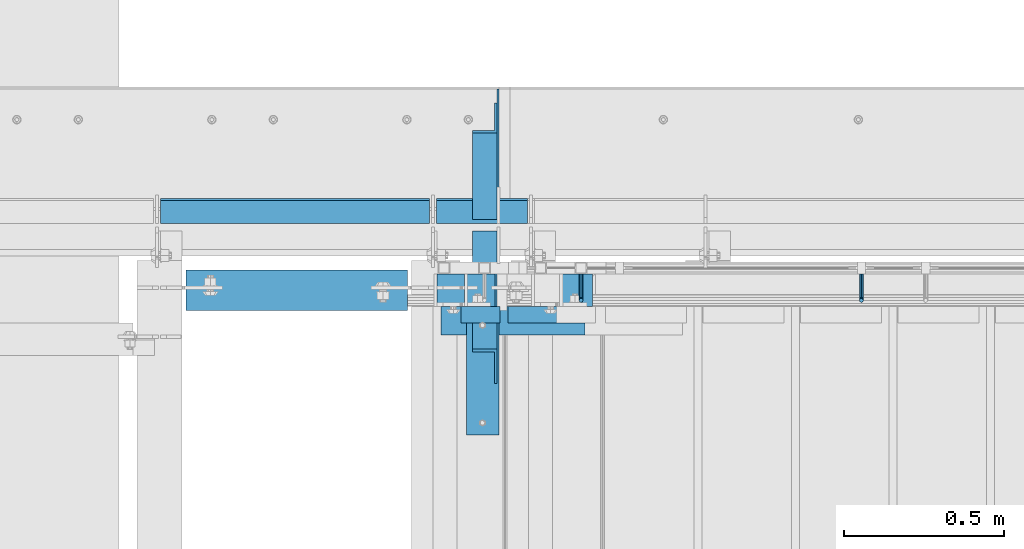
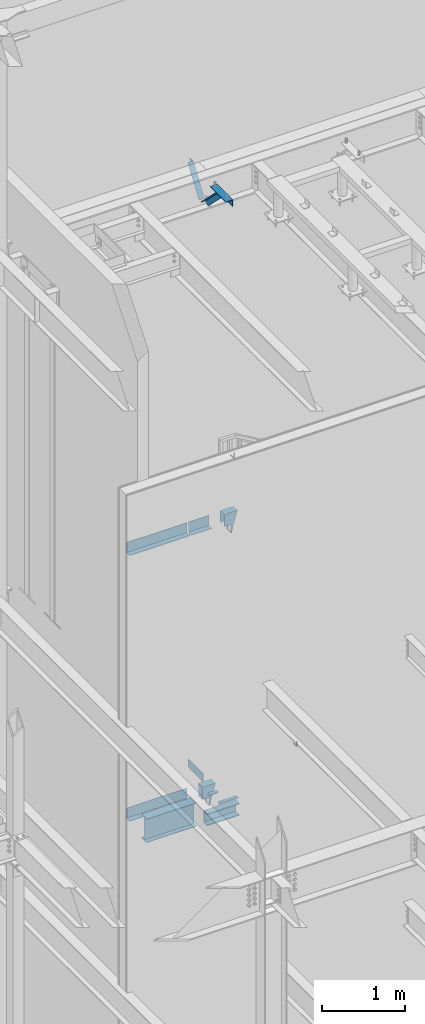
# One storey, part 935 of 1179: 14 beams, 2 members, 10 elements without a shape of their own.
"""IFC2X3 building model written with IfcOpenShell, lengths in millimetres."""

import ifcopenshell
import ifcopenshell.guid

model = None  # the IFC model being written
_history = None  # IfcOwnerHistory: only IFC2X3 demands one
_inside = {}  # id of a spatial element -> (the spatial element, [elements in it])
_under = {}  # id of a project, library or spatial element -> (it, [spatial elements below it])
_declared = {}  # id of a project -> (the project, [libraries it declares])
_typed = {}  # id of a type object -> (the type object, [elements of that type])
_made_of = {}  # id of a material, layer set ... -> (it, [elements and type objects made of it])


def new_model(schema):
    """Start an empty IFC model of exactly this schema.

    Asked for "IFC4X3", IfcOpenShell would pick the latest addendum, in which some entities
    have other attributes; the version numbers below select the first issue.
    IFC2X3 requires an IfcOwnerHistory on every rooted entity: one is made here for all.
    """
    global model, _history
    if schema == "IFC4X3":
        model = ifcopenshell.file(schema_version=(4, 3, 0, 0))
    else:
        model = ifcopenshell.file(schema=schema)
    _inside.clear()
    _under.clear()
    _declared.clear()
    _typed.clear()
    _made_of.clear()
    _history = None
    if model.schema == "IFC2X3":
        org = make("IfcOrganization", Name="unknown")
        user = make(
            "IfcPersonAndOrganization",
            ThePerson=make("IfcPerson", FamilyName="unknown"),
            TheOrganization=org,
        )
        app = make(
            "IfcApplication",
            ApplicationDeveloper=org,
            Version="unknown",
            ApplicationFullName="unknown",
            ApplicationIdentifier="unknown",
        )
        _history = make(
            "IfcOwnerHistory",
            OwningUser=user,
            OwningApplication=app,
            ChangeAction="ADDED",
            CreationDate=0,
        )
    return model


def make(cls, **values):
    """One entity of the class cls with the attributes given. An attribute that is None is left unset."""
    return model.create_entity(
        cls, **{name: value for name, value in values.items() if value is not None}
    )


def rooted(cls, **values):
    """An entity with a GlobalId (a new one), such as an element, a storey or a relation."""
    return make(cls, GlobalId=ifcopenshell.guid.new(), OwnerHistory=_history, **values)


def si_unit(unit_type, name, prefix=None):
    """IfcSIUnit, for example si_unit("LENGTHUNIT", "METRE", prefix="MILLI")."""
    return make("IfcSIUnit", UnitType=unit_type, Prefix=prefix, Name=name)


def assignment(units):
    """IfcUnitAssignment: the units of a project."""
    return None if units is None else make("IfcUnitAssignment", Units=units)


def point(xyz):
    """IfcCartesianPoint."""
    return None if xyz is None else make("IfcCartesianPoint", Coordinates=xyz)


def direction(xyz):
    """IfcDirection."""
    return None if xyz is None else make("IfcDirection", DirectionRatios=xyz)


def frame(location, z_axis=None, x_axis=None):
    """IfcAxis2Placement3D, a coordinate frame: its origin and axes. An axis left out is left unset."""
    return make(
        "IfcAxis2Placement3D",
        Location=point(location),
        Axis=direction(z_axis),
        RefDirection=direction(x_axis),
    )


def origin_with_axes():
    """The frame at (0, 0, 0) with the z axis (0, 0, 1) and the x axis (1, 0, 0) written out."""
    return frame((0.0, 0.0, 0.0), z_axis=(0.0, 0.0, 1.0), x_axis=(1.0, 0.0, 0.0))


def place(relative_to, where):
    """IfcLocalPlacement: puts the frame where relative to a parent placement (None: the world)."""
    return make(
        "IfcLocalPlacement", PlacementRelTo=relative_to, RelativePlacement=where
    )


def context(
    kind, dimensions, precision=None, world=None, true_north=None, identifier=None
):
    """IfcGeometricRepresentationContext, for example the 3D "Model" context."""
    return make(
        "IfcGeometricRepresentationContext",
        ContextIdentifier=identifier,
        ContextType=kind,
        CoordinateSpaceDimension=dimensions,
        Precision=precision,
        WorldCoordinateSystem=world,
        TrueNorth=true_north,
    )


def subcontext(parent, identifier, kind, view, scale=None):
    """IfcGeometricRepresentationSubContext, for example "Body" below "Model"."""
    return make(
        "IfcGeometricRepresentationSubContext",
        ContextIdentifier=identifier,
        ContextType=kind,
        ParentContext=parent,
        TargetScale=scale,
        TargetView=view,
    )


def project(units=None, contexts=None):
    """IfcProject with its units and contexts."""
    return rooted(
        "IfcProject",
        Name="project",
        RepresentationContexts=contexts,
        UnitsInContext=assignment(units),
    )


def spatial(cls, under=None, at=None, **own):
    """A site, building, storey or space (cls), placed at a placement, below another one or the project."""
    s = rooted(cls, ObjectPlacement=at, **own)
    if under is not None:
        _under.setdefault(under.id(), (under, []))[1].append(s)
    return s


def faces_of(points, faces, orient=None, outer=None):
    """IfcFace entities. A face is a list of loops; a loop is a list of indices into points, from 0.

    orient and outer hold one flag for each loop. By default every Orientation is true, the
    first loop of a face is its IfcFaceOuterBound and the others are IfcFaceBound.
    """
    made = []
    for i, loops in enumerate(faces):
        bounds = []
        for j, loop in enumerate(loops):
            is_outer = j == 0 if outer is None else outer[i][j]
            bounds.append(
                make(
                    "IfcFaceOuterBound" if is_outer else "IfcFaceBound",
                    Bound=make("IfcPolyLoop", Polygon=[points[k] for k in loop]),
                    Orientation=True if orient is None else orient[i][j],
                )
            )
        made.append(make("IfcFace", Bounds=bounds))
    return made


def faceted_brep(points, faces, orient=None, outer=None, voids=None):
    """IfcFacetedBrep: a solid bounded by flat faces; with voids (closed shells), ...WithVoids."""
    shared = [point(p) for p in points]
    hull = make("IfcClosedShell", CfsFaces=faces_of(shared, faces, orient, outer))
    if voids is None:
        return make("IfcFacetedBrep", Outer=hull)
    return make(
        "IfcFacetedBrepWithVoids",
        Outer=hull,
        Voids=[
            make(cls, CfsFaces=faces_of(shared, fs, o, b)) for cls, fs, o, b in voids
        ],
    )


def shape(context_of_items, identifier, shape_type, items):
    """IfcShapeRepresentation: the items that make up one representation, for example the "Body"."""
    return make(
        "IfcShapeRepresentation",
        ContextOfItems=context_of_items,
        RepresentationIdentifier=identifier,
        RepresentationType=shape_type,
        Items=items,
    )


def material(Name=None, Category=None):
    """IfcMaterial."""
    return make("IfcMaterial", Name=Name, Category=Category)


def made_of(thing, what):
    """Note that an element or type object is made of a material, layer set ...; save() writes the relation."""
    if what is not None:
        _made_of.setdefault(what.id(), (what, []))[1].append(thing)
    return thing


def type_object(cls, material=None, **own):
    """A type object (cls), such as IfcWallType, which elements share."""
    return made_of(rooted(cls, **own), material)


def element(
    cls,
    number,
    at=None,
    inside=None,
    cuts=None,
    type_object=None,
    material=None,
    context=None,
    identifier="Body",
    shape_type=None,
    held_by="IfcProductDefinitionShape",
    body=None,
    shapes=None,
    **own,
):
    """One element of the class cls, such as IfcWall. Its Tag is "e" and its number.

    at: its placement. inside: the storey or other place that contains it. cuts: it is an
    opening in that element (IfcRelVoidsElement). A single representation is given by context,
    identifier, shape_type and body (its items); several are given by shapes. held_by: the class
    of the entity that holds the representations. save() writes the other relations.
    """
    e = rooted(cls, Tag="e%d" % number, ObjectPlacement=at, **own)
    if body is not None:
        shapes = [shape(context, identifier, shape_type, body)]
    if shapes is not None:
        e.Representation = make(held_by, Representations=shapes)
    if inside is not None:
        _inside.setdefault(inside.id(), (inside, []))[1].append(e)
    if cuts is not None:
        rooted(
            "IfcRelVoidsElement", RelatingBuildingElement=cuts, RelatedOpeningElement=e
        )
    if type_object is not None:
        _typed.setdefault(type_object.id(), (type_object, []))[1].append(e)
    return made_of(e, material)


def aggregate(whole, parts):
    """IfcRelAggregates: a whole, such as a stair, and the parts it consists of."""
    return rooted("IfcRelAggregates", RelatingObject=whole, RelatedObjects=parts)


def save(model, path):
    """Write the relations noted so far, then the file.

    IfcRelAggregates (storeys below a building ...), IfcRelContainedInSpatialStructure (elements
    in a storey), IfcRelDefinesByType, IfcRelAssociatesMaterial and IfcRelDeclares: one each for
    every whole, place, type object, material and project.
    """
    for whole, parts in _under.values():
        aggregate(whole, parts)
    for where, things in _inside.values():
        rooted(
            "IfcRelContainedInSpatialStructure",
            RelatedElements=things,
            RelatingStructure=where,
        )
    for kind, things in _typed.values():
        rooted("IfcRelDefinesByType", RelatedObjects=things, RelatingType=kind)
    for what, things in _made_of.values():
        rooted("IfcRelAssociatesMaterial", RelatedObjects=things, RelatingMaterial=what)
    for by, libraries in _declared.values():
        rooted("IfcRelDeclares", RelatingContext=by, RelatedDefinitions=libraries)
    model.write(path)


model = new_model("IFC2X3")

# Units and contexts
model_context = context("Model", 3, precision=1e-05, world=origin_with_axes())
body_context = subcontext(model_context, "Body", "Model", "MODEL_VIEW")
ifc_project = project(units=[si_unit("LENGTHUNIT", "METRE", prefix="MILLI"), si_unit("AREAUNIT", "SQUARE_METRE"), si_unit("VOLUMEUNIT", "CUBIC_METRE"), si_unit("MASSUNIT", "GRAM", prefix="KILO"), si_unit("TIMEUNIT", "SECOND"), si_unit("PLANEANGLEUNIT", "RADIAN"), si_unit("SOLIDANGLEUNIT", "STERADIAN"), si_unit("THERMODYNAMICTEMPERATUREUNIT", "DEGREE_CELSIUS"), si_unit("LUMINOUSINTENSITYUNIT", "LUMEN")], contexts=[model_context])

# Site, building, storey
site_placement = place(None, origin_with_axes())
site = spatial("IfcSite", under=ifc_project, at=site_placement, CompositionType="ELEMENT")
building_placement = place(site_placement, origin_with_axes())
building = spatial("IfcBuilding", under=site, at=building_placement, Name="Undefined", CompositionType="ELEMENT")
storey_placement = place(building_placement, origin_with_axes())
storey = spatial("IfcBuildingStorey", under=building, at=storey_placement, Name="Undefined", CompositionType="ELEMENT", Elevation=0.0)

# Assembly, beams
assembly_1_placement = place(storey_placement, origin_with_axes())
assembly_1 = element("IfcElementAssembly", 1, at=assembly_1_placement, inside=storey, Name="STAIR", AssemblyPlace="NOTDEFINED", PredefinedType="RIGID_FRAME")
ifc_material_1 = material(Name="STEEL/A36")
beam_type_1 = type_object("IfcBeamType", Name="L2X2X3/16", PredefinedType="NOTDEFINED")
beam_1_placement = place(assembly_1_placement, frame((19478.6250374759, 40919.4000000076, 4156.67030071397), z_axis=(2.54499999937252e-06, 0.0, -0.999999999996761), x_axis=(-0.999999999996761, 0.0, -2.5449999982255e-06)))
beam_1 = element("IfcBeam", 2, at=beam_1_placement, type_object=beam_type_1, material=ifc_material_1, Name="ANGLE", ObjectType="L2X2X3/16", context=body_context, shape_type="Brep", body=[
    faceted_brep([(0.0, 25.3999999999996, -25.4000000000015), (0.0, 25.3999999999996, 25.4000000000015), (120.650000000842, 25.3999999999996, 25.4000000000015), (120.650000000842, 25.3999999999996, -25.4000000000015), (0.0, 20.6374999999998, 25.4000000000015), (120.650000000842, 20.6374999999998, 25.4000000000015), (0.0, 20.6374999999998, -20.6374999999971), (120.650000000842, 20.6374999999998, -20.6374999999971), (0.0, -25.3999999999996, -20.6374999999971), (120.650000000842, -25.3999999999996, -20.6374999999971), (0.0, -25.3999999999996, -25.4000000000015), (120.650000000842, -25.3999999999996, -25.4000000000015)], [[[0, 1, 2, 3]], [[1, 4, 5, 2]], [[4, 6, 7, 5]], [[6, 8, 9, 7]], [[8, 10, 11, 9]], [[10, 0, 3, 11]], [[5, 7, 9, 11, 3, 2]], [[10, 8, 6, 4, 1, 0]]]),
])
beam_2_placement = place(assembly_1_placement, frame((19503.632173545, 40919.4000001359, 3980.19321612137), z_axis=(0.0, -1.0, 0.0), x_axis=(1.0, 0.0, 0.0)))
beam_2 = element("IfcBeam", 3, at=beam_2_placement, type_object=beam_type_1, material=ifc_material_1, Name="ANGLE", ObjectType="L2X2X3/16", context=body_context, shape_type="Brep", body=[
    faceted_brep([(0.0, 25.3999999999996, -25.4000000000015), (0.0, 25.3999999999996, 25.4000000000015), (254.0, 25.3999999999996, 25.4000000000001), (254.0, 25.3999999999996, -25.4000000000001), (0.0, 20.6374999999998, 25.4000000000015), (254.0, 20.6374999999998, 25.4000000000001), (0.0, 20.6374999999998, -20.6374999999971), (254.0, 20.6374999999998, -20.6374999999998), (0.0, -25.3999999999996, -20.6374999999971), (254.0, -25.3999999999996, -20.6374999999998), (0.0, -25.3999999999996, -25.4000000000015), (254.0, -25.3999999999996, -25.4000000000001)], [[[0, 1, 2, 3]], [[1, 4, 5, 2]], [[4, 6, 7, 5]], [[6, 8, 9, 7]], [[8, 10, 11, 9]], [[10, 0, 3, 11]], [[5, 7, 9, 11, 3, 2]], [[10, 8, 6, 4, 1, 0]]]),
])

# Assembly, beam
assembly_2_placement = place(storey_placement, origin_with_axes())
assembly_2 = element("IfcElementAssembly", 4, at=assembly_2_placement, inside=storey, Name="GUARDRAIL", AssemblyPlace="NOTDEFINED", PredefinedType="RIGID_FRAME")
beam_type_2 = type_object("IfcBeamType", PredefinedType="NOTDEFINED")
beam_3_placement = place(assembly_2_placement, frame((19732.5169379626, 41046.3999992099, 8966.20000066328), z_axis=(0.0, 0.0, 1.0), x_axis=(0.0, -1.0, 0.0)))
beam_3 = element("IfcBeam", 5, at=beam_3_placement, type_object=beam_type_2, material=ifc_material_1, Name="BRACKET", context=body_context, shape_type="Brep", body=[
    faceted_brep([(0.0, -4.49012806053361, 4.49012806053452), (0.0, 0.0, 6.34999999999991), (0.0, 4.49012806053361, 4.49012806053452), (0.0, 6.34999999999854, 0.0), (0.0, 4.49012806053361, -4.49012806053452), (0.0, 0.0, -6.34999999999991), (0.0, -4.49012806053361, -4.49012806053452), (0.0, -6.34999999999854, 0.0), (69.849999425729, 0.0, -6.34999999999991), (69.849999425729, -4.49012806053361, -4.49012806053452), (69.849999425729, -6.34999999999854, 0.0), (69.849999425729, -4.49012806053361, 4.49012806053452), (69.849999425729, 0.0, 6.34999999999991), (69.849999425729, 4.49012806053361, 4.49012806053452), (69.849999425729, 6.34999999999854, 0.0), (69.849999425729, 4.49012806053361, -4.49012806053452), (78.445063360632, 4.49012806053361, -2.18708762028064), (79.3749993303718, 0.0, -3.79778396764323), (78.445063360632, -4.49012806053361, -2.18708762028064), (76.1999993303689, -6.34999999999854, 1.70147734638658), (73.9549353000984, -4.49012806053361, 5.59004231305425), (73.024999330366, 0.0, 7.20073866041639), (73.9549353000984, 4.49012806053361, 5.59004231305425), (76.1999993303689, 6.34999999999854, 1.70147734638658), (80.8485218886053, 6.34999999999854, 6.34999990462893), (84.7370868552753, 4.49012806053361, 4.10493587436031), (76.9599569219426, 4.49012806053361, 8.59506393489755), (75.3492605745778, 0.0, 9.52499990463093), (76.9599569219426, -4.49012806053361, 8.59506393489755), (80.8485218886053, -6.34999999999854, 6.34999990462893), (84.7370868552753, -4.49012806053361, 4.10493587436031), (86.3477832026401, 0.0, 3.17499990462693), (87.0401272955278, 4.49012806053361, 12.6999998092651), (88.8999992349927, 0.0, 12.6999998092651), (82.5499992349942, 6.34999999999854, 12.6999998092651), (78.0598711744606, 4.49012806053361, 12.6999998092651), (76.1999992349956, 0.0, 12.6999998092651), (78.0598711744606, -4.49012806053361, 12.6999998092651), (82.5499992349942, -6.34999999999854, 12.6999998092651), (87.0401272955278, -4.49012806053361, 12.6999998092651), (88.8999992349927, 0.0, 76.2000000000003), (87.0401272955278, -4.49012806053361, 76.2000000000007), (82.5499992349942, -6.34999999999854, 76.2000000000007), (78.0598711744606, -4.49012806053361, 76.2000000000007), (76.1999992349956, 0.0, 76.2000000000003), (78.0598711744606, 4.49012806053361, 76.2000000000007), (82.5499992349942, 6.34999999999854, 76.2000000000007), (87.0401272955278, 4.49012806053361, 76.2000000000007)], [[[0, 1, 2, 3, 4, 5, 6, 7]], [[6, 5, 8, 9]], [[7, 6, 9, 10]], [[0, 7, 10, 11]], [[1, 0, 11, 12]], [[2, 1, 12, 13]], [[3, 2, 13, 14]], [[4, 3, 14, 15]], [[5, 4, 15, 8]], [[8, 15, 16, 17]], [[9, 8, 17, 18]], [[10, 9, 18, 19]], [[11, 10, 19, 20]], [[12, 11, 20, 21]], [[13, 12, 21, 22]], [[14, 13, 22, 23]], [[15, 14, 23, 16]], [[23, 24, 25, 16]], [[22, 26, 24, 23]], [[21, 27, 26, 22]], [[20, 28, 27, 21]], [[19, 29, 28, 20]], [[18, 30, 29, 19]], [[17, 31, 30, 18]], [[16, 25, 31, 17]], [[25, 32, 33, 31]], [[24, 34, 32, 25]], [[26, 35, 34, 24]], [[27, 36, 35, 26]], [[28, 37, 36, 27]], [[29, 38, 37, 28]], [[30, 39, 38, 29]], [[31, 33, 39, 30]], [[39, 33, 40, 41]], [[38, 39, 41, 42]], [[37, 38, 42, 43]], [[36, 37, 43, 44]], [[35, 36, 44, 45]], [[34, 35, 45, 46]], [[32, 34, 46, 47]], [[33, 32, 47, 40]], [[40, 47, 46, 45, 44, 43, 42, 41]]]),
])
aggregate(assembly_2, [beam_3])

assembly_3_placement = place(storey_placement, origin_with_axes())
assembly_3 = element("IfcElementAssembly", 6, at=assembly_3_placement, inside=storey, Name="GUARDRAIL", AssemblyPlace="NOTDEFINED", PredefinedType="RIGID_FRAME")
beam_4_placement = place(assembly_3_placement, frame((20608.9249611478, 41046.3999992163, 4410.06958368114), z_axis=(0.0, 0.0, 1.0), x_axis=(0.0, -1.0, 0.0)))
beam_4 = element("IfcBeam", 7, at=beam_4_placement, type_object=beam_type_2, material=ifc_material_1, Name="BRACKET", context=body_context, shape_type="Brep", body=[
    faceted_brep([(0.0, -4.49012806053361, 4.49012806053452), (0.0, 0.0, 6.34999999999991), (0.0, 4.49012806053361, 4.49012806053452), (0.0, 6.34999999999854, 0.0), (0.0, 4.49012806053361, -4.49012806053452), (0.0, 0.0, -6.34999999999991), (0.0, -4.49012806053361, -4.49012806053452), (0.0, -6.34999999999854, 0.0), (69.849999425729, 0.0, -6.34999999999991), (69.849999425729, -4.49012806053361, -4.49012806053452), (69.849999425729, -6.34999999999854, 0.0), (69.849999425729, -4.49012806053361, 4.49012806053452), (69.849999425729, 0.0, 6.34999999999991), (69.849999425729, 4.49012806053361, 4.49012806053452), (69.849999425729, 6.34999999999854, 0.0), (69.849999425729, 4.49012806053361, -4.49012806053452), (78.445063360632, 4.49012806053361, -2.18708762028064), (79.3749993303718, 0.0, -3.79778396764323), (78.445063360632, -4.49012806053361, -2.18708762028064), (76.1999993303689, -6.34999999999854, 1.70147734638658), (73.9549353000984, -4.49012806053361, 5.59004231305425), (73.024999330366, 0.0, 7.20073866041639), (73.9549353000984, 4.49012806053361, 5.59004231305425), (76.1999993303689, 6.34999999999854, 1.70147734638658), (80.8485218886053, 6.34999999999854, 6.34999990462893), (84.7370868552753, 4.49012806053361, 4.10493587436031), (76.9599569219426, 4.49012806053361, 8.59506393489755), (75.3492605745778, 0.0, 9.52499990463093), (76.9599569219426, -4.49012806053361, 8.59506393489755), (80.8485218886053, -6.34999999999854, 6.34999990462893), (84.7370868552753, -4.49012806053361, 4.10493587436031), (86.3477832026401, 0.0, 3.17499990462693), (87.0401272955278, 4.49012806053361, 12.6999998092651), (88.8999992349927, 0.0, 12.6999998092651), (82.5499992349942, 6.34999999999854, 12.6999998092651), (78.0598711744606, 4.49012806053361, 12.6999998092651), (76.1999992349956, 0.0, 12.6999998092651), (78.0598711744606, -4.49012806053361, 12.6999998092651), (82.5499992349942, -6.34999999999854, 12.6999998092651), (87.0401272955278, -4.49012806053361, 12.6999998092651), (88.8999992349927, 0.0, 76.2000000000003), (87.0401272908275, -4.49012806053361, 78.7997529672102), (82.5499992302939, -6.34999999999854, 79.8766059046975), (78.0598711697603, -4.49012806053361, 78.7997529672102), (76.1999992349956, 0.0, 76.2000000000003), (78.0598711697603, 4.49012806053361, 73.6002470344774), (82.5499992302939, 6.34999999999854, 72.5233940969902), (87.0401272908275, 4.49012806053361, 73.6002470344774)], [[[0, 1, 2, 3, 4, 5, 6, 7]], [[6, 5, 8, 9]], [[7, 6, 9, 10]], [[0, 7, 10, 11]], [[1, 0, 11, 12]], [[2, 1, 12, 13]], [[3, 2, 13, 14]], [[4, 3, 14, 15]], [[5, 4, 15, 8]], [[8, 15, 16, 17]], [[9, 8, 17, 18]], [[10, 9, 18, 19]], [[11, 10, 19, 20]], [[12, 11, 20, 21]], [[13, 12, 21, 22]], [[14, 13, 22, 23]], [[15, 14, 23, 16]], [[23, 24, 25, 16]], [[22, 26, 24, 23]], [[21, 27, 26, 22]], [[20, 28, 27, 21]], [[19, 29, 28, 20]], [[18, 30, 29, 19]], [[17, 31, 30, 18]], [[16, 25, 31, 17]], [[25, 32, 33, 31]], [[24, 34, 32, 25]], [[26, 35, 34, 24]], [[27, 36, 35, 26]], [[28, 37, 36, 27]], [[29, 38, 37, 28]], [[30, 39, 38, 29]], [[31, 33, 39, 30]], [[39, 33, 40, 41]], [[38, 39, 41, 42]], [[37, 38, 42, 43]], [[36, 37, 43, 44]], [[35, 36, 44, 45]], [[34, 35, 45, 46]], [[32, 34, 46, 47]], [[33, 32, 47, 40]], [[46, 45, 44, 43, 42, 41, 40, 47]]]),
])
aggregate(assembly_3, [beam_4])

assembly_4_placement = place(storey_placement, origin_with_axes())
assembly_4 = element("IfcElementAssembly", 8, at=assembly_4_placement, inside=storey, Name="BEAM", AssemblyPlace="NOTDEFINED", PredefinedType="RIGID_FRAME")
ifc_material_2 = material(Name="STEEL/A992")
beam_type_3 = type_object("IfcBeamType", Name="W14X22", PredefinedType="NOTDEFINED")
beam_5_placement = place(assembly_4_placement, frame((18415.0, 40995.6000000682, 3927.475), z_axis=(0.0, 0.0, 1.0), x_axis=(1.0, 0.0, 0.0)))
beam_5 = element("IfcBeam", 9, at=beam_5_placement, type_object=beam_type_3, material=ifc_material_2, Name="BEAM", ObjectType="W14X22", context=body_context, shape_type="Brep", body=[
    faceted_brep([(82.5499999999993, -63.5, -174.625), (82.5499999999993, 63.5, -174.625), (774.700000000001, 63.5, -174.625), (774.700000000001, -63.5, -174.625), (82.5499999999993, -63.5, -166.6875), (82.5499999999993, -3.17500000000291, -166.6875), (82.5499999999993, -3.17500000000291, 166.6875), (82.5499999999993, -63.5, 166.6875), (82.5499999999993, -63.5, 174.625), (82.5499999999993, 63.5, 174.625), (82.5499999999993, 63.5, 166.6875), (82.5499999999993, 3.17500000000291, 166.6875), (82.5499999999993, 3.17500000000291, 137.265000000114), (82.5499999999993, 3.17500000000291, -92.8149999999623), (82.5499999999993, 3.17500000000291, -166.6875), (82.5499999999993, 63.5, -166.6875), (774.700000000001, -63.5, -166.6875), (774.700000000001, -3.17500000000291, -166.6875), (774.700000000001, -3.17500000000291, 166.6875), (774.700000000001, -63.5, 166.6875), (774.700000000001, -63.5, 174.625), (774.700000000001, 63.5, 174.625), (774.700000000001, 63.5, 166.6875), (774.700000000001, 3.17500000000291, 166.6875), (774.700000000001, 3.17500000000291, 137.265000000132), (774.700000000001, 3.17500000000291, -92.8149999999441), (774.700000000001, 3.17500000000291, -166.6875), (774.700000000001, 63.5, -166.6875)], [[[0, 1, 2, 3]], [[0, 4, 5, 6, 7, 8, 9, 10, 11, 12, 13, 14, 15, 1]], [[5, 4, 16, 17]], [[6, 5, 17, 18]], [[7, 6, 18, 19]], [[8, 7, 19, 20]], [[9, 8, 20, 21]], [[10, 9, 21, 22]], [[11, 10, 22, 23]], [[14, 13, 12, 11, 23, 24, 25, 26]], [[15, 14, 26, 27]], [[1, 15, 27, 2]], [[26, 25, 24, 23, 22, 21, 20, 19, 18, 17, 16, 3, 2, 27]], [[4, 0, 3, 16]]]),
])
aggregate(assembly_4, [beam_5])

# Assembly, member
assembly_5_placement = place(storey_placement, origin_with_axes())
assembly_5 = element("IfcElementAssembly", 10, at=assembly_5_placement, inside=storey, Name="ANGLE", AssemblyPlace="NOTDEFINED", PredefinedType="RIGID_FRAME")
member_type = type_object("IfcMemberType", Name="L3X3X1/4", PredefinedType="NOTDEFINED")
member_1_placement = place(assembly_5_placement, frame((19431.0, 40704.7386537876, 13150.1502196524), z_axis=(0.0, -0.706388288025418, -0.707824545025474), x_axis=(0.0, 0.707824545025473, -0.706388288025419)))
member_1 = element("IfcMember", 11, at=member_1_placement, type_object=member_type, material=ifc_material_1, Name="ANGLE", ObjectType="L3X3X1/4", context=body_context, shape_type="Brep", body=[
    faceted_brep([(634.184990526992, 31.75, 38.0999999999767), (634.184990526996, 31.75, -31.7499999999636), (634.184990526996, -38.0999999999985, -31.7499999999636), (634.184990526996, -38.0999999999985, -38.0999999999549), (634.184990526996, 38.0999999999985, -38.0999999999549), (634.184990526992, 38.0999999999985, 38.0999999999767), (113.596638248473, -38.0999999999985, -38.0999999999549), (113.596638248473, 38.0999999999985, -38.0999999999549), (37.2417053522113, 38.0999999999985, 38.0999999999694), (37.2417053522113, 31.75, 38.0999999999694), (107.233727173789, 31.75, -31.7499999999709), (107.233727173789, -38.0999999999985, -31.7499999999709)], [[[0, 1, 2, 3, 4, 5]], [[4, 3, 6, 7]], [[5, 4, 7, 8]], [[0, 5, 8, 9]], [[1, 0, 9, 10]], [[2, 1, 10, 11]], [[3, 2, 11, 6]], [[10, 9, 8, 7, 6, 11]]]),
])
aggregate(assembly_5, [member_1])

assembly_6_placement = place(storey_placement, origin_with_axes())
assembly_6 = element("IfcElementAssembly", 12, at=assembly_6_placement, inside=storey, Name="ANGLE", AssemblyPlace="NOTDEFINED", PredefinedType="RIGID_FRAME")
member_2_placement = place(assembly_6_placement, frame((19431.0, 41248.3636551321, 12707.4244380128), z_axis=(0.0, 0.821716663099518, -0.569896241069015), x_axis=(0.0, 0.569896241069016, 0.821716663099518)))
member_2 = element("IfcMember", 13, at=member_2_placement, type_object=member_type, material=ifc_material_1, Name="ANGLE", ObjectType="L3X3X1/4", context=body_context, shape_type="Brep", body=[
    faceted_brep([(0.0, -38.0999999999985, -38.0999999999999), (0.0, -38.0999999999985, -31.75), (0.0, 31.75, -31.75), (0.0, 31.75, 38.1000000000004), (0.0, 38.0999999999985, 38.0999999999999), (0.0, 38.0999999999985, -38.0999999999999), (527.418547333735, 31.75, 38.0999999993364), (527.418547333735, 38.1000000000004, 38.0999999993364), (474.570533511644, 38.1000000000004, -38.1000000006607), (474.570533511644, -38.1000000000004, -38.1000000006607), (478.974534663488, -38.1000000000004, -31.7500000006621), (478.974534663488, 31.75, -31.7500000006621)], [[[0, 1, 2, 3, 4, 5]], [[4, 3, 6, 7]], [[5, 4, 7, 8]], [[0, 5, 8, 9]], [[1, 0, 9, 10]], [[2, 1, 10, 11]], [[3, 2, 11, 6]], [[10, 9, 8, 7, 6, 11]]]),
])
aggregate(assembly_6, [member_2])

# Beam
beam_type_4 = type_object("IfcBeamType", Name="MC7X19.1", PredefinedType="NOTDEFINED")
beam_6_placement = place(assembly_1_placement, frame((19295.26875, 40900.3500000081, 3855.77291612159), z_axis=(0.0, 0.0, 1.0), x_axis=(1.0, 0.0, 0.0)))
beam_6 = element("IfcBeam", 14, at=beam_6_placement, type_object=beam_type_4, material=ifc_material_1, Name="BEAM", ObjectType="MC7X19.1", context=body_context, shape_type="Brep", body=[
    faceted_brep([(0.0, 44.4499999999971, -88.9000000000001), (0.0, 44.4499999999971, 88.9000000000001), (449.291786109603, 44.4499999999971, 88.9000000000001), (449.291786109603, 44.4499999999971, -88.9000000000001), (0.0, -44.4499999999971, 88.9000000000001), (449.291786109603, -44.4499999999971, 88.9000000000001), (0.0, -44.4499999999971, 77.0845549999999), (449.291786109603, -44.4499999999971, 77.0845549999999), (0.0, 34.9250000000029, 75.5049924999998), (449.291786109603, 34.9250000000029, 75.5049924999998), (0.0, 34.9250000000029, -75.5049924999998), (449.291786109603, 34.9250000000029, -75.5049924999998), (0.0, -44.4499999999971, -77.0845549999999), (449.291786109603, -44.4499999999971, -77.0845549999999), (0.0, -44.4499999999971, -88.9000000000001), (449.291786109603, -44.4499999999971, -88.9000000000001)], [[[0, 1, 2, 3]], [[1, 4, 5, 2]], [[4, 6, 7, 5]], [[6, 8, 9, 7]], [[8, 10, 11, 9]], [[10, 12, 13, 11]], [[12, 14, 15, 13]], [[14, 0, 3, 15]], [[5, 7, 9, 11, 13, 15, 3, 2]], [[14, 12, 10, 8, 6, 4, 1, 0]]]),
])

# Assembly, beam
assembly_7_placement = place(storey_placement, origin_with_axes())
assembly_7 = element("IfcElementAssembly", 15, at=assembly_7_placement, inside=storey, Name="BEAM", AssemblyPlace="NOTDEFINED", PredefinedType="RIGID_FRAME")
beam_type_5 = type_object("IfcBeamType", PredefinedType="NOTDEFINED")
beam_7_placement = place(assembly_7_placement, frame((19423.0622500839, 41204.3562513898, 7845.42500614864), z_axis=(-1.0, 0.0, 0.0), x_axis=(0.0, 1.0, 0.0)))
beam_7 = element("IfcBeam", 16, at=beam_7_placement, type_object=beam_type_5, material=ifc_material_1, Name="BENT_PLATE", context=body_context, shape_type="Brep", body=[
    faceted_brep([(1.0113581083715e-09, -3.17500000000018, -142.0815), (5.3114490583539e-10, -3.17500000000018, 142.0815), (-1.02591002359986e-09, 3.17500000000018, 142.0815), (-5.45696821063757e-10, 3.17500000000018, -142.0815), (78.5812123189098, 3.17500001945882, 142.081499999844), (78.5812123191208, 3.17500001945882, -142.081500000153), (72.2312118237969, -3.17499998211406, -142.081500000142), (72.2312118235859, -3.17499998211406, 142.081499999858), (78.5812004310283, -149.224999975485, 142.081499999702), (78.5812004314939, -149.224999975218, -142.081500000299), (72.2312004310224, -149.224999480174, 142.081499999716), (72.2312004314881, -149.224999479908, -142.081500000284)], [[[0, 1, 2, 3]], [[3, 2, 4, 5]], [[1, 0, 6, 7]], [[5, 4, 8, 9]], [[4, 2, 1, 7, 10, 8]], [[7, 6, 11, 10]], [[6, 0, 3, 5, 9, 11]], [[10, 11, 9, 8]]]),
])

assembly_8_placement = place(storey_placement, origin_with_axes())
assembly_8 = element("IfcElementAssembly", 17, at=assembly_8_placement, inside=storey, Name="BEAM", AssemblyPlace="NOTDEFINED", PredefinedType="RIGID_FRAME")
beam_8_placement = place(assembly_8_placement, frame((18838.8620000839, 41204.3562660259, 3933.82500614879), z_axis=(-1.0, 0.0, 0.0), x_axis=(0.0, 1.0, 0.0)))
beam_8 = element("IfcBeam", 18, at=beam_8_placement, type_object=beam_type_5, material=ifc_material_1, Name="BENT_PLATE", context=body_context, shape_type="Brep", body=[
    faceted_brep([(1.46974343806505e-09, -3.17500000000064, -420.6875), (7.27595761418343e-11, -3.17500000000064, 420.6875), (-1.48429535329342e-09, 3.17499999999973, 420.6875), (-8.73114913702011e-11, 3.17499999999973, -420.6875), (78.5812123301439, 3.17500001945837, 420.687499999844), (78.5812123307478, 3.17500001945837, -420.687500000156), (72.2312118354239, -3.17499998211406, -420.687500000142), (72.23121183482, -3.17499998211406, 420.687499999858), (78.5812004420077, -149.224999964323, 420.687499999702), (78.5812004433683, -149.224999963534, -420.687500000298), (72.2312004420091, -149.224999469011, 420.687499999716), (72.2312004433697, -149.224999468222, -420.687500000284)], [[[0, 1, 2, 3]], [[3, 2, 4, 5]], [[1, 0, 6, 7]], [[5, 4, 8, 9]], [[4, 2, 1, 7, 10, 8]], [[7, 6, 11, 10]], [[6, 0, 3, 5, 9, 11]], [[10, 11, 9, 8]]]),
])

# Beam
beam_9_placement = place(assembly_7_placement, frame((18838.8620000839, 41204.3562536004, 7845.42500614864), z_axis=(-1.0, 0.0, 0.0), x_axis=(0.0, 1.0, 0.0)))
beam_9 = element("IfcBeam", 19, at=beam_9_placement, type_object=beam_type_5, material=ifc_material_1, Name="BENT_PLATE", context=body_context, shape_type="Brep", body=[
    faceted_brep([(1.46974343806505e-09, -3.17500000000064, -420.6875), (7.27595761418343e-11, -3.17500000000064, 420.6875), (-1.48429535329342e-09, 3.17499999999973, 420.6875), (-8.73114913702011e-11, 3.17499999999973, -420.6875), (78.5812123301439, 3.17500001945837, 420.687499999844), (78.5812123307478, 3.17500001945837, -420.687500000156), (72.2312118354239, -3.17499998211406, -420.687500000142), (72.23121183482, -3.17499998211406, 420.687499999858), (78.5812004420077, -149.224999964323, 420.687499999702), (78.5812004433683, -149.224999963534, -420.687500000298), (72.2312004420091, -149.224999469011, 420.687499999716), (72.2312004433697, -149.224999468222, -420.687500000284)], [[[0, 1, 2, 3]], [[3, 2, 4, 5]], [[1, 0, 6, 7]], [[5, 4, 8, 9]], [[4, 2, 1, 7, 10, 8]], [[7, 6, 11, 10]], [[6, 0, 3, 5, 9, 11]], [[10, 11, 9, 8]]]),
])

aggregate(assembly_7, [beam_7, beam_9])

beam_type_6 = type_object("IfcBeamType", PredefinedType="NOTDEFINED")
beam_10_placement = place(assembly_1_placement, frame((19367.4999996928, 40995.6000000849, 4106.86250013859), z_axis=(0.0, -1.0, 0.0), x_axis=(-1.0, 0.0, 0.0)))
beam_10 = element("IfcBeam", 20, at=beam_10_placement, type_object=beam_type_6, material=ifc_material_1, Name="PLATE", context=body_context, shape_type="Brep", body=[
    faceted_brep([(0.0, 4.76249999999982, -50.7999999999993), (0.0, 4.76249999999982, 50.7999999999993), (85.7249992897196, 4.76249999999982, 50.8000000000029), (85.7249992897196, 4.76249999999982, -50.8000000000029), (0.0, -4.76249999999982, 50.7999999999993), (85.7249992897196, -4.76249999999982, 50.8000000000029), (0.0, -4.76249999999982, -50.7999999999993), (85.7249992897196, -4.76249999999982, -50.8000000000029)], [[[0, 1, 2, 3]], [[1, 4, 5, 2]], [[4, 6, 7, 5]], [[6, 0, 3, 7]], [[5, 7, 3, 2]], [[6, 4, 1, 0]]]),
])

ifc_material_3 = material()
beam_type_7 = type_object("IfcBeamType", Name="HSS12X4X3/8", PredefinedType="NOTDEFINED")
beam_11_placement = place(assembly_1_placement, frame((19463.8034063526, 40995.5999999626, 4133.84999940983), z_axis=(0.0, 0.0, 1.0), x_axis=(-1.0, 0.0, 0.0)))
beam_11 = element("IfcBeam", 21, at=beam_11_placement, type_object=beam_type_7, material=ifc_material_3, Name="STAIR", ObjectType="HSS12X4X3/8", context=body_context, shape_type="Brep", body=[
    faceted_brep([(182.028405929726, 41.2750000000015, -22.2249992769102), (86.7784065394517, 41.2750000000015, -22.2249992769002), (86.7784065394517, 50.8000000000029, -22.2249992769002), (182.028405929726, 50.8000000000029, -22.2249992769102), (86.7784069338013, -50.8000000000029, -152.4), (86.7784069338013, 50.8000000000029, -152.4), (86.7784069049449, 41.2750000000015, -142.875), (86.7784069049449, -41.2750000000015, -142.875), (86.7784065394517, -41.2750000000015, -22.2249992769002), (86.7784065394517, -50.8000000000029, -22.2249992769002), (182.028405795554, -50.8000000000029, -22.2249992769102), (182.028405929726, -41.2750000000015, -22.2249992769102), (182.028405929726, 41.2750000000015, 142.875), (2.55849975384263, 41.2750000000015, 142.875), (79.3135518111412, 41.2750000000015, -142.875), (2.55849975384263, -41.2750000000015, 142.875), (182.028405929726, -41.2750000000015, 142.875), (79.3135518111412, -41.2750000000015, -142.875), (81.8720535463835, -50.8000000000029, -152.4), (0.0, -50.8000000000029, 152.4), (0.0, 50.8000000000029, 152.4), (81.8720535463835, 50.8000000000029, -152.4), (182.028405919682, -50.8000000000029, 152.4), (182.028405919682, 50.8000000000029, 152.4)], [[[0, 1, 2, 3]], [[4, 5, 2, 1, 6, 7, 8, 9]], [[10, 9, 8, 11]], [[12, 13, 14, 6, 1, 0]], [[15, 13, 12, 16]], [[7, 17, 15, 16, 11, 8]], [[14, 17, 7, 6]], [[18, 19, 20, 21], [13, 15, 17, 14]], [[20, 19, 22, 23]], [[16, 12, 0, 3, 23, 22, 10, 11]], [[5, 21, 20, 23, 3, 2]], [[18, 21, 5, 4]], [[22, 19, 18, 4, 9, 10]]]),
])

aggregate(assembly_1, [beam_1, beam_2, beam_10, beam_11, beam_6])

# Assembly, beam
assembly_9_placement = place(storey_placement, origin_with_axes())
assembly_9 = element("IfcElementAssembly", 22, at=assembly_9_placement, inside=storey, Name="STAIR", AssemblyPlace="NOTDEFINED", PredefinedType="RIGID_FRAME")
beam_12_placement = place(assembly_9_placement, frame((19768.9740138743, 40995.600000006, 8045.45000001041), z_axis=(0.0, 0.0, 1.0), x_axis=(-1.0, 0.0, 0.0)))
beam_12 = element("IfcBeam", 23, at=beam_12_placement, type_object=beam_type_7, material=ifc_material_3, Name="STAIR", ObjectType="HSS12X4X3/8", context=body_context, shape_type="Brep", body=[
    faceted_brep([(182.399011088342, 41.2750000000015, -22.2250000067716), (93.4990269453774, 41.2750000000015, -22.2250000068952), (93.4990269453774, 50.8000000000029, -22.2250000068952), (182.399011088342, 50.8000000000029, -22.2250000067716), (93.4990057263785, -50.8000000000029, -152.4), (93.4990057263785, 50.8000000000029, -152.4), (93.4990072789878, 41.2750000000015, -142.875), (93.4990072789878, -41.2750000000015, -142.875), (93.4990269453774, -41.2750000000015, -22.2250000068952), (93.4990269453774, -50.8000000000029, -22.2250000068952), (182.399013949253, -50.8000000000029, -22.2250000067716), (182.399011088342, -41.2750000000015, -22.2250000067716), (182.399011088342, 41.2750000000015, 142.875), (2.57507555327538, 41.2750000000015, 142.875), (79.827342666882, 41.2750000000015, -142.875), (2.57507555327538, -41.2750000000015, 142.875), (182.399011088342, -41.2750000000015, 142.875), (79.827342666882, -41.2750000000015, -142.875), (82.402418237336, -50.8000000000029, -152.4), (0.0, -50.8000000000029, 152.4), (0.0, 50.8000000000029, 152.4), (82.402418237336, 50.8000000000029, -152.4), (182.399011069894, -50.8000000000029, 152.4), (182.399011069894, 50.8000000000029, 152.4)], [[[0, 1, 2, 3]], [[4, 5, 2, 1, 6, 7, 8, 9]], [[10, 9, 8, 11]], [[12, 13, 14, 6, 1, 0]], [[15, 13, 12, 16]], [[7, 17, 15, 16, 11, 8]], [[14, 17, 7, 6]], [[18, 19, 20, 21], [13, 15, 17, 14]], [[20, 19, 22, 23]], [[16, 12, 0, 3, 23, 22, 10, 11]], [[5, 21, 20, 23, 3, 2]], [[18, 21, 5, 4]], [[22, 19, 18, 4, 9, 10]]]),
])
aggregate(assembly_9, [beam_12])

assembly_10_placement = place(storey_placement, origin_with_axes())
assembly_10 = element("IfcElementAssembly", 24, at=assembly_10_placement, inside=storey, Name="ANGLE", AssemblyPlace="NOTDEFINED", PredefinedType="RIGID_FRAME")
beam_type_8 = type_object("IfcBeamType", Name="L4X4X1/4", PredefinedType="NOTDEFINED")
beam_13_placement = place(assembly_10_placement, frame((19424.649999998, 40924.162499953, 13068.3), z_axis=(-1.0, 0.0, 0.0), x_axis=(0.0, -1.0, 0.0)))
beam_13 = element("IfcBeam", 25, at=beam_13_placement, type_object=beam_type_8, material=ifc_material_1, Name="ANGLE", ObjectType="L4X4X1/4", context=body_context, shape_type="Brep", body=[
    faceted_brep([(1.90993887372315e-11, 50.8000000000002, -50.8000000000002), (1.90993887372315e-11, 50.8000000000002, 50.8000000000002), (381.0, 50.8000000000002, 50.7999999999993), (381.0, 50.8000000000002, -50.7999999999993), (0.0, 44.4500000000007, 50.8000000000002), (381.0, 44.4499999999998, 50.7999999999993), (0.0, 44.4500000000007, -44.4499999999998), (381.0, 44.4499999999998, -44.4500000000007), (0.0, -50.7999999999993, -44.4499999999998), (381.0, -50.8000000000002, -44.4500000000007), (-1.81898940354586e-11, -50.7999999999997, -50.8000000000002), (381.0, -50.8000000000002, -50.7999999999993)], [[[0, 1, 2, 3]], [[1, 4, 5, 2]], [[4, 6, 7, 5]], [[6, 8, 9, 7]], [[8, 10, 11, 9]], [[10, 0, 3, 11]], [[5, 7, 9, 11, 3, 2]], [[10, 8, 6, 4, 1, 0]]]),
])
aggregate(assembly_10, [beam_13])

# Beam
beam_type_9 = type_object("IfcBeamType", PredefinedType="NOTDEFINED")
beam_14_placement = place(assembly_8_placement, frame((19472.2749769497, 41254.3625, 4171.95000610352), z_axis=(0.0, 0.0, 1.0), x_axis=(0.0, 1.0, 0.0)))
beam_14 = element("IfcBeam", 26, at=beam_14_placement, type_object=beam_type_9, material=ifc_material_1, Name="PLATE", context=body_context, shape_type="Brep", body=[
    faceted_brep([(369.887500284567, -3.17499999942083, -44.4499999999998), (350.837500284564, -3.17499999944994, -63.5), (350.837500284557, 3.17500000055225, -63.5), (369.887500284553, 3.17500000057771, -44.4499999999998), (0.0, 3.17499999999927, -63.5), (0.0, 3.17499999999927, 63.5), (369.887500284553, 3.17500000057771, 63.5), (0.0, -3.17499999999927, 63.5), (369.887500284567, -3.17499999942083, 63.5), (0.0, -3.17499999999927, -63.5)], [[[0, 1, 2, 3]], [[4, 5, 6, 3, 2]], [[5, 7, 8, 6]], [[8, 7, 9, 1, 0]], [[9, 4, 2, 1]], [[6, 8, 0, 3]], [[9, 7, 5, 4]]]),
])

aggregate(assembly_8, [beam_8, beam_14])

save(model, "model.ifc")
